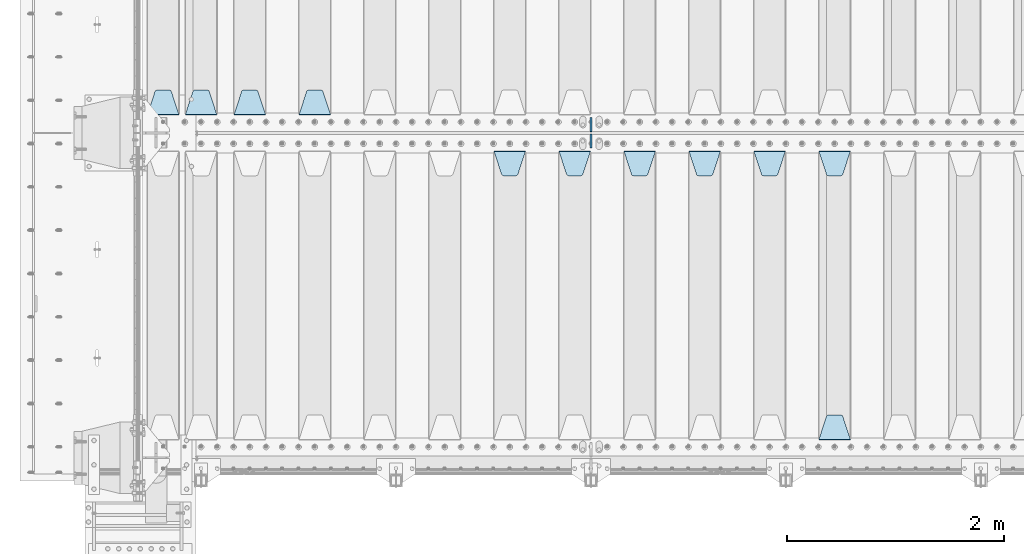
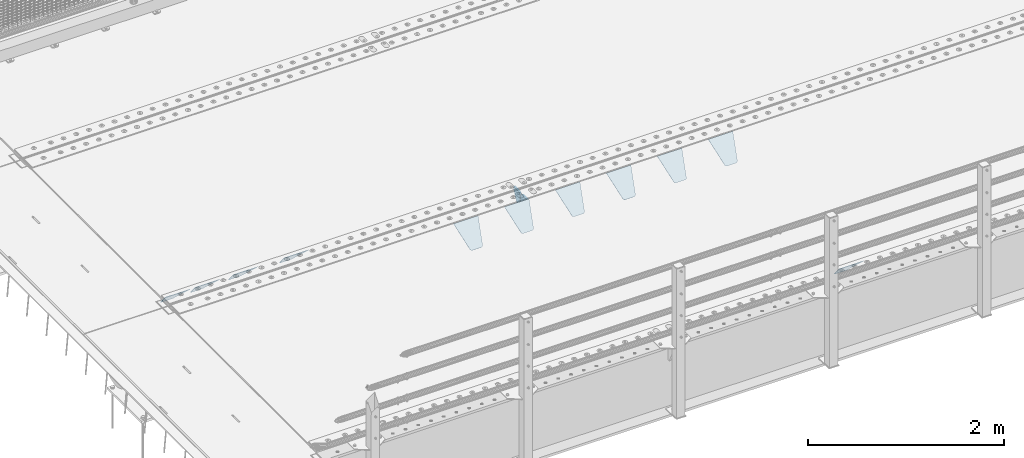
# One storey, part 177 of 219: 13 plates.
"""IFC2X3 building model written with IfcOpenShell, lengths in millimetres."""

from ifc_helpers import new_model, si_unit, frame, origin_with_axes, place, context, subcontext, project, spatial, faceted_brep, material, type_object, element, save


model = new_model("IFC2X3")

# Units and contexts
model_context = context("Model", 3, precision=1e-05, world=origin_with_axes())
body_context = subcontext(model_context, "Body", "Model", "MODEL_VIEW")
ifc_project = project(units=[si_unit("LENGTHUNIT", "METRE", prefix="MILLI"), si_unit("AREAUNIT", "SQUARE_METRE"), si_unit("VOLUMEUNIT", "CUBIC_METRE"), si_unit("MASSUNIT", "GRAM", prefix="KILO"), si_unit("TIMEUNIT", "SECOND"), si_unit("PLANEANGLEUNIT", "RADIAN"), si_unit("SOLIDANGLEUNIT", "STERADIAN"), si_unit("THERMODYNAMICTEMPERATUREUNIT", "DEGREE_CELSIUS"), si_unit("LUMINOUSINTENSITYUNIT", "LUMEN")], contexts=[model_context])

# Site, building, storey
site_placement = place(None, origin_with_axes())
site = spatial("IfcSite", under=ifc_project, at=site_placement, CompositionType="ELEMENT")
building_placement = place(site_placement, origin_with_axes())
building = spatial("IfcBuilding", under=site, at=building_placement, Name="Standard", CompositionType="ELEMENT")
storey_placement = place(building_placement, origin_with_axes())
storey = spatial("IfcBuildingStorey", under=building, at=storey_placement, Name="Undefined", CompositionType="ELEMENT", Elevation=0.0)

# Plates
ifc_material = material(Name="STEEL/S355N")
plate_type_1 = type_object("IfcPlateType", PredefinedType="NOTDEFINED")
plate_1_placement = place(storey_placement, frame((6255.0, 26831.767766956, -1.76776695296758), z_axis=(0.0, -0.707106781186547, -0.707106781186548), x_axis=(1.0, 0.0, 0.0)))
element("IfcPlate", 1, at=plate_1_placement, inside=storey, type_object=plate_type_1, material=ifc_material, context=body_context, shape_type="Brep", body=[
    faceted_brep([(0.0, -2.5, 0.0), (69.345504679477, -2.5, 300.171731424834), (69.345504679477, 2.49999999999636, 300.171731424831), (0.0, 2.5, 0.0), (70.9274061199576, -2.50000000000364, 304.8974424154), (70.9274061199576, 2.49999999999636, 304.8974424154), (73.3818627772307, -2.50000000000364, 309.234538108532), (73.3818627772307, 2.49999999999636, 309.234538108532), (76.6187032999569, -2.50000000000364, 313.023683126106), (76.6187032999569, 2.49999999999636, 313.023683126106), (80.5190132704993, -2.50000000000364, 316.125672595372), (80.5190132704993, 2.49999999999636, 316.125672595372), (84.9395038596831, -2.50000000000364, 318.426546230476), (84.9395038596831, 2.5, 318.426546230479), (89.7177759439237, -2.50000000000364, 319.841774983277), (89.7177759439237, 2.5, 319.841774983281), (94.6782862926502, -2.50000000000364, 320.319366455078), (94.6782862926502, 2.49999999999636, 320.319366455078), (195.32171370735, -2.50000000000364, 320.319366455078), (195.32171370735, 2.49999999999636, 320.319366455078), (200.282224056076, -2.50000000000364, 319.841774983277), (200.282224056076, 2.5, 319.841774983281), (205.060496140317, -2.50000000000364, 318.426546230476), (205.060496140317, 2.49999999999636, 318.426546230476), (209.480986729501, -2.50000000000364, 316.125672595372), (209.480986729501, 2.49999999999636, 316.125672595372), (213.381296700043, -2.50000000000364, 313.023683126106), (213.381296700043, 2.49999999999272, 313.023683126106), (216.618137222769, -2.50000000000364, 309.234538108529), (216.618137222769, 2.49999999999636, 309.234538108525), (219.072593880042, -2.50000000000364, 304.8974424154), (219.072593880042, 2.49999999999636, 304.8974424154), (220.654495320523, -2.5, 300.171731424834), (220.654495320523, 2.49999999999636, 300.171731424831), (290.0, -2.50000000000364, 3.63797880709171e-12), (290.0, 2.49999999999636, 0.0)], [[[0, 1, 2, 3]], [[1, 4, 5, 2]], [[4, 6, 7, 5]], [[6, 8, 9, 7]], [[8, 10, 11, 9]], [[10, 12, 13, 11]], [[12, 14, 15, 13]], [[14, 16, 17, 15]], [[16, 18, 19, 17]], [[18, 20, 21, 19]], [[20, 22, 23, 21]], [[22, 24, 25, 23]], [[24, 26, 27, 25]], [[26, 28, 29, 27]], [[28, 30, 31, 29]], [[30, 32, 33, 31]], [[32, 34, 35, 33]], [[34, 0, 3, 35]], [[5, 7, 9, 11, 13, 15, 17, 19, 21, 23, 25, 27, 29, 31, 33, 35, 3, 2]], [[34, 32, 30, 28, 26, 24, 22, 20, 18, 16, 14, 12, 10, 8, 6, 4, 1, 0]]]),
])
plate_2_placement = place(storey_placement, frame((6545.0, 24168.232233047, -1.76776695296758), z_axis=(0.0, 0.707106781186547, -0.707106781186548), x_axis=(-1.0, 0.0, 0.0)))
element("IfcPlate", 2, at=plate_2_placement, inside=storey, type_object=plate_type_1, material=ifc_material, context=body_context, shape_type="Brep", body=[
    faceted_brep([(0.0, -2.5, 0.0), (69.345504679477, -2.5, 300.171731424834), (69.345504679477, 2.49999999999636, 300.171731424831), (0.0, 2.5, 0.0), (70.9274061199576, -2.50000000000364, 304.8974424154), (70.9274061199576, 2.49999999999636, 304.8974424154), (73.3818627772307, -2.50000000000364, 309.234538108532), (73.3818627772307, 2.49999999999636, 309.234538108532), (76.6187032999569, -2.50000000000364, 313.023683126106), (76.6187032999569, 2.49999999999636, 313.023683126106), (80.5190132704993, -2.50000000000364, 316.125672595372), (80.5190132704993, 2.49999999999636, 316.125672595372), (84.9395038596831, -2.50000000000364, 318.426546230476), (84.9395038596831, 2.5, 318.426546230479), (89.7177759439237, -2.50000000000364, 319.841774983277), (89.7177759439237, 2.5, 319.841774983281), (94.6782862926502, -2.50000000000364, 320.319366455078), (94.6782862926502, 2.49999999999636, 320.319366455078), (195.32171370735, -2.50000000000364, 320.319366455078), (195.32171370735, 2.49999999999636, 320.319366455078), (200.282224056076, -2.50000000000364, 319.841774983277), (200.282224056076, 2.5, 319.841774983281), (205.060496140317, -2.50000000000364, 318.426546230476), (205.060496140317, 2.49999999999636, 318.426546230476), (209.480986729501, -2.50000000000364, 316.125672595372), (209.480986729501, 2.49999999999636, 316.125672595372), (213.381296700043, -2.50000000000364, 313.023683126106), (213.381296700043, 2.49999999999272, 313.023683126106), (216.618137222769, -2.50000000000364, 309.234538108529), (216.618137222769, 2.49999999999636, 309.234538108525), (219.072593880042, -2.50000000000364, 304.8974424154), (219.072593880042, 2.49999999999636, 304.8974424154), (220.654495320523, -2.5, 300.171731424834), (220.654495320523, 2.49999999999636, 300.171731424831), (290.0, -2.50000000000364, 3.63797880709171e-12), (290.0, 2.49999999999636, 0.0)], [[[0, 1, 2, 3]], [[1, 4, 5, 2]], [[4, 6, 7, 5]], [[6, 8, 9, 7]], [[8, 10, 11, 9]], [[10, 12, 13, 11]], [[12, 14, 15, 13]], [[14, 16, 17, 15]], [[16, 18, 19, 17]], [[18, 20, 21, 19]], [[20, 22, 23, 21]], [[22, 24, 25, 23]], [[24, 26, 27, 25]], [[26, 28, 29, 27]], [[28, 30, 31, 29]], [[30, 32, 33, 31]], [[32, 34, 35, 33]], [[34, 0, 3, 35]], [[5, 7, 9, 11, 13, 15, 17, 19, 21, 23, 25, 27, 29, 31, 33, 35, 3, 2]], [[34, 32, 30, 28, 26, 24, 22, 20, 18, 16, 14, 12, 10, 8, 6, 4, 1, 0]]]),
])
plate_3_placement = place(storey_placement, frame((5655.0, 26831.767766956, -1.76776695296758), z_axis=(0.0, -0.707106781186547, -0.707106781186548), x_axis=(1.0, 0.0, 0.0)))
element("IfcPlate", 3, at=plate_3_placement, inside=storey, type_object=plate_type_1, material=ifc_material, context=body_context, shape_type="Brep", body=[
    faceted_brep([(0.0, -2.5, 0.0), (69.345504679477, -2.5, 300.171731424834), (69.345504679477, 2.49999999999636, 300.171731424831), (0.0, 2.5, 0.0), (70.9274061199576, -2.50000000000364, 304.8974424154), (70.9274061199576, 2.49999999999636, 304.8974424154), (73.3818627772307, -2.50000000000364, 309.234538108532), (73.3818627772307, 2.49999999999636, 309.234538108532), (76.6187032999569, -2.50000000000364, 313.023683126106), (76.6187032999569, 2.49999999999636, 313.023683126106), (80.5190132704993, -2.50000000000364, 316.125672595372), (80.5190132704993, 2.49999999999636, 316.125672595372), (84.9395038596831, -2.50000000000364, 318.426546230476), (84.9395038596831, 2.5, 318.426546230479), (89.7177759439237, -2.50000000000364, 319.841774983277), (89.7177759439237, 2.5, 319.841774983281), (94.6782862926502, -2.50000000000364, 320.319366455078), (94.6782862926502, 2.49999999999636, 320.319366455078), (195.32171370735, -2.50000000000364, 320.319366455078), (195.32171370735, 2.49999999999636, 320.319366455078), (200.282224056076, -2.50000000000364, 319.841774983277), (200.282224056076, 2.5, 319.841774983281), (205.060496140317, -2.50000000000364, 318.426546230476), (205.060496140317, 2.49999999999636, 318.426546230476), (209.480986729501, -2.50000000000364, 316.125672595372), (209.480986729501, 2.49999999999636, 316.125672595372), (213.381296700043, -2.50000000000364, 313.023683126106), (213.381296700043, 2.49999999999272, 313.023683126106), (216.618137222769, -2.50000000000364, 309.234538108529), (216.618137222769, 2.49999999999636, 309.234538108525), (219.072593880042, -2.50000000000364, 304.8974424154), (219.072593880042, 2.49999999999636, 304.8974424154), (220.654495320523, -2.5, 300.171731424834), (220.654495320523, 2.49999999999636, 300.171731424831), (290.0, -2.50000000000364, 3.63797880709171e-12), (290.0, 2.49999999999636, 0.0)], [[[0, 1, 2, 3]], [[1, 4, 5, 2]], [[4, 6, 7, 5]], [[6, 8, 9, 7]], [[8, 10, 11, 9]], [[10, 12, 13, 11]], [[12, 14, 15, 13]], [[14, 16, 17, 15]], [[16, 18, 19, 17]], [[18, 20, 21, 19]], [[20, 22, 23, 21]], [[22, 24, 25, 23]], [[24, 26, 27, 25]], [[26, 28, 29, 27]], [[28, 30, 31, 29]], [[30, 32, 33, 31]], [[32, 34, 35, 33]], [[34, 0, 3, 35]], [[5, 7, 9, 11, 13, 15, 17, 19, 21, 23, 25, 27, 29, 31, 33, 35, 3, 2]], [[34, 32, 30, 28, 26, 24, 22, 20, 18, 16, 14, 12, 10, 8, 6, 4, 1, 0]]]),
])
plate_4_placement = place(storey_placement, frame((5055.0, 26831.767766956, -1.76776695296758), z_axis=(0.0, -0.707106781186547, -0.707106781186548), x_axis=(1.0, 0.0, 0.0)))
element("IfcPlate", 4, at=plate_4_placement, inside=storey, type_object=plate_type_1, material=ifc_material, context=body_context, shape_type="Brep", body=[
    faceted_brep([(0.0, -2.5, 0.0), (69.345504679477, -2.5, 300.171731424834), (69.345504679477, 2.49999999999636, 300.171731424831), (0.0, 2.5, 0.0), (70.9274061199576, -2.50000000000364, 304.8974424154), (70.9274061199576, 2.49999999999636, 304.8974424154), (73.3818627772307, -2.50000000000364, 309.234538108532), (73.3818627772307, 2.49999999999636, 309.234538108532), (76.6187032999569, -2.50000000000364, 313.023683126106), (76.6187032999569, 2.49999999999636, 313.023683126106), (80.5190132704993, -2.50000000000364, 316.125672595372), (80.5190132704993, 2.49999999999636, 316.125672595372), (84.9395038596831, -2.50000000000364, 318.426546230476), (84.9395038596831, 2.5, 318.426546230479), (89.7177759439237, -2.50000000000364, 319.841774983277), (89.7177759439237, 2.5, 319.841774983281), (94.6782862926502, -2.50000000000364, 320.319366455078), (94.6782862926502, 2.49999999999636, 320.319366455078), (195.32171370735, -2.50000000000364, 320.319366455078), (195.32171370735, 2.49999999999636, 320.319366455078), (200.282224056076, -2.50000000000364, 319.841774983277), (200.282224056076, 2.5, 319.841774983281), (205.060496140317, -2.50000000000364, 318.426546230476), (205.060496140317, 2.49999999999636, 318.426546230476), (209.480986729501, -2.50000000000364, 316.125672595372), (209.480986729501, 2.49999999999636, 316.125672595372), (213.381296700043, -2.50000000000364, 313.023683126106), (213.381296700043, 2.49999999999272, 313.023683126106), (216.618137222769, -2.50000000000364, 309.234538108529), (216.618137222769, 2.49999999999636, 309.234538108525), (219.072593880042, -2.50000000000364, 304.8974424154), (219.072593880042, 2.49999999999636, 304.8974424154), (220.654495320523, -2.5, 300.171731424834), (220.654495320523, 2.49999999999636, 300.171731424831), (290.0, -2.50000000000364, 3.63797880709171e-12), (290.0, 2.49999999999636, 0.0)], [[[0, 1, 2, 3]], [[1, 4, 5, 2]], [[4, 6, 7, 5]], [[6, 8, 9, 7]], [[8, 10, 11, 9]], [[10, 12, 13, 11]], [[12, 14, 15, 13]], [[14, 16, 17, 15]], [[16, 18, 19, 17]], [[18, 20, 21, 19]], [[20, 22, 23, 21]], [[22, 24, 25, 23]], [[24, 26, 27, 25]], [[26, 28, 29, 27]], [[28, 30, 31, 29]], [[30, 32, 33, 31]], [[32, 34, 35, 33]], [[34, 0, 3, 35]], [[5, 7, 9, 11, 13, 15, 17, 19, 21, 23, 25, 27, 29, 31, 33, 35, 3, 2]], [[34, 32, 30, 28, 26, 24, 22, 20, 18, 16, 14, 12, 10, 8, 6, 4, 1, 0]]]),
])
plate_5_placement = place(storey_placement, frame((4455.0, 26831.767766956, -1.76776695296758), z_axis=(0.0, -0.707106781186547, -0.707106781186548), x_axis=(1.0, 0.0, 0.0)))
element("IfcPlate", 5, at=plate_5_placement, inside=storey, type_object=plate_type_1, material=ifc_material, context=body_context, shape_type="Brep", body=[
    faceted_brep([(0.0, -2.5, 0.0), (69.345504679477, -2.5, 300.171731424834), (69.345504679477, 2.49999999999636, 300.171731424831), (0.0, 2.5, 0.0), (70.9274061199576, -2.50000000000364, 304.8974424154), (70.9274061199576, 2.49999999999636, 304.8974424154), (73.3818627772307, -2.50000000000364, 309.234538108532), (73.3818627772307, 2.49999999999636, 309.234538108532), (76.6187032999569, -2.50000000000364, 313.023683126106), (76.6187032999569, 2.49999999999636, 313.023683126106), (80.5190132704993, -2.50000000000364, 316.125672595372), (80.5190132704993, 2.49999999999636, 316.125672595372), (84.9395038596831, -2.50000000000364, 318.426546230476), (84.9395038596831, 2.5, 318.426546230479), (89.7177759439237, -2.50000000000364, 319.841774983277), (89.7177759439237, 2.5, 319.841774983281), (94.6782862926502, -2.50000000000364, 320.319366455078), (94.6782862926502, 2.49999999999636, 320.319366455078), (195.32171370735, -2.50000000000364, 320.319366455078), (195.32171370735, 2.49999999999636, 320.319366455078), (200.282224056076, -2.50000000000364, 319.841774983277), (200.282224056076, 2.5, 319.841774983281), (205.060496140317, -2.50000000000364, 318.426546230476), (205.060496140317, 2.49999999999636, 318.426546230476), (209.480986729501, -2.50000000000364, 316.125672595372), (209.480986729501, 2.49999999999636, 316.125672595372), (213.381296700043, -2.50000000000364, 313.023683126106), (213.381296700043, 2.49999999999272, 313.023683126106), (216.618137222769, -2.50000000000364, 309.234538108529), (216.618137222769, 2.49999999999636, 309.234538108525), (219.072593880042, -2.50000000000364, 304.8974424154), (219.072593880042, 2.49999999999636, 304.8974424154), (220.654495320523, -2.5, 300.171731424834), (220.654495320523, 2.49999999999636, 300.171731424831), (290.0, -2.50000000000364, 3.63797880709171e-12), (290.0, 2.49999999999636, 0.0)], [[[0, 1, 2, 3]], [[1, 4, 5, 2]], [[4, 6, 7, 5]], [[6, 8, 9, 7]], [[8, 10, 11, 9]], [[10, 12, 13, 11]], [[12, 14, 15, 13]], [[14, 16, 17, 15]], [[16, 18, 19, 17]], [[18, 20, 21, 19]], [[20, 22, 23, 21]], [[22, 24, 25, 23]], [[24, 26, 27, 25]], [[26, 28, 29, 27]], [[28, 30, 31, 29]], [[30, 32, 33, 31]], [[32, 34, 35, 33]], [[34, 0, 3, 35]], [[5, 7, 9, 11, 13, 15, 17, 19, 21, 23, 25, 27, 29, 31, 33, 35, 3, 2]], [[34, 32, 30, 28, 26, 24, 22, 20, 18, 16, 14, 12, 10, 8, 6, 4, 1, 0]]]),
])
plate_6_placement = place(storey_placement, frame((3855.0, 26831.767766956, -1.76776695296758), z_axis=(0.0, -0.707106781186547, -0.707106781186548), x_axis=(1.0, 0.0, 0.0)))
element("IfcPlate", 6, at=plate_6_placement, inside=storey, type_object=plate_type_1, material=ifc_material, context=body_context, shape_type="Brep", body=[
    faceted_brep([(0.0, -2.5, 0.0), (69.345504679477, -2.5, 300.171731424834), (69.345504679477, 2.49999999999636, 300.171731424831), (0.0, 2.5, 0.0), (70.9274061199576, -2.50000000000364, 304.8974424154), (70.9274061199576, 2.49999999999636, 304.8974424154), (73.3818627772307, -2.50000000000364, 309.234538108532), (73.3818627772307, 2.49999999999636, 309.234538108532), (76.6187032999569, -2.50000000000364, 313.023683126106), (76.6187032999569, 2.49999999999636, 313.023683126106), (80.5190132704993, -2.50000000000364, 316.125672595372), (80.5190132704993, 2.49999999999636, 316.125672595372), (84.9395038596831, -2.50000000000364, 318.426546230476), (84.9395038596831, 2.5, 318.426546230479), (89.7177759439237, -2.50000000000364, 319.841774983277), (89.7177759439237, 2.5, 319.841774983281), (94.6782862926502, -2.50000000000364, 320.319366455078), (94.6782862926502, 2.49999999999636, 320.319366455078), (195.32171370735, -2.50000000000364, 320.319366455078), (195.32171370735, 2.49999999999636, 320.319366455078), (200.282224056076, -2.50000000000364, 319.841774983277), (200.282224056076, 2.5, 319.841774983281), (205.060496140317, -2.50000000000364, 318.426546230476), (205.060496140317, 2.49999999999636, 318.426546230476), (209.480986729501, -2.50000000000364, 316.125672595372), (209.480986729501, 2.49999999999636, 316.125672595372), (213.381296700043, -2.50000000000364, 313.023683126106), (213.381296700043, 2.49999999999272, 313.023683126106), (216.618137222769, -2.50000000000364, 309.234538108529), (216.618137222769, 2.49999999999636, 309.234538108525), (219.072593880042, -2.50000000000364, 304.8974424154), (219.072593880042, 2.49999999999636, 304.8974424154), (220.654495320523, -2.5, 300.171731424834), (220.654495320523, 2.49999999999636, 300.171731424831), (290.0, -2.50000000000364, 3.63797880709171e-12), (290.0, 2.49999999999636, 0.0)], [[[0, 1, 2, 3]], [[1, 4, 5, 2]], [[4, 6, 7, 5]], [[6, 8, 9, 7]], [[8, 10, 11, 9]], [[10, 12, 13, 11]], [[12, 14, 15, 13]], [[14, 16, 17, 15]], [[16, 18, 19, 17]], [[18, 20, 21, 19]], [[20, 22, 23, 21]], [[22, 24, 25, 23]], [[24, 26, 27, 25]], [[26, 28, 29, 27]], [[28, 30, 31, 29]], [[30, 32, 33, 31]], [[32, 34, 35, 33]], [[34, 0, 3, 35]], [[5, 7, 9, 11, 13, 15, 17, 19, 21, 23, 25, 27, 29, 31, 33, 35, 3, 2]], [[34, 32, 30, 28, 26, 24, 22, 20, 18, 16, 14, 12, 10, 8, 6, 4, 1, 0]]]),
])
plate_7_placement = place(storey_placement, frame((3255.0, 26831.767766956, -1.76776695296758), z_axis=(0.0, -0.707106781186547, -0.707106781186548), x_axis=(1.0, 0.0, 0.0)))
element("IfcPlate", 7, at=plate_7_placement, inside=storey, type_object=plate_type_1, material=ifc_material, context=body_context, shape_type="Brep", body=[
    faceted_brep([(0.0, -2.5, 0.0), (69.345504679477, -2.5, 300.171731424834), (69.345504679477, 2.49999999999636, 300.171731424831), (0.0, 2.5, 0.0), (70.9274061199576, -2.50000000000364, 304.8974424154), (70.9274061199576, 2.49999999999636, 304.8974424154), (73.3818627772307, -2.50000000000364, 309.234538108532), (73.3818627772307, 2.49999999999636, 309.234538108532), (76.6187032999569, -2.50000000000364, 313.023683126106), (76.6187032999569, 2.49999999999636, 313.023683126106), (80.5190132704993, -2.50000000000364, 316.125672595372), (80.5190132704993, 2.49999999999636, 316.125672595372), (84.9395038596831, -2.50000000000364, 318.426546230476), (84.9395038596831, 2.5, 318.426546230479), (89.7177759439237, -2.50000000000364, 319.841774983277), (89.7177759439237, 2.5, 319.841774983281), (94.6782862926502, -2.50000000000364, 320.319366455078), (94.6782862926502, 2.49999999999636, 320.319366455078), (195.32171370735, -2.50000000000364, 320.319366455078), (195.32171370735, 2.49999999999636, 320.319366455078), (200.282224056076, -2.50000000000364, 319.841774983277), (200.282224056076, 2.5, 319.841774983281), (205.060496140317, -2.50000000000364, 318.426546230476), (205.060496140317, 2.49999999999636, 318.426546230476), (209.480986729501, -2.50000000000364, 316.125672595372), (209.480986729501, 2.49999999999636, 316.125672595372), (213.381296700043, -2.50000000000364, 313.023683126106), (213.381296700043, 2.49999999999272, 313.023683126106), (216.618137222769, -2.50000000000364, 309.234538108529), (216.618137222769, 2.49999999999636, 309.234538108525), (219.072593880042, -2.50000000000364, 304.8974424154), (219.072593880042, 2.49999999999636, 304.8974424154), (220.654495320523, -2.5, 300.171731424834), (220.654495320523, 2.49999999999636, 300.171731424831), (290.0, -2.50000000000364, 3.63797880709171e-12), (290.0, 2.49999999999636, 0.0)], [[[0, 1, 2, 3]], [[1, 4, 5, 2]], [[4, 6, 7, 5]], [[6, 8, 9, 7]], [[8, 10, 11, 9]], [[10, 12, 13, 11]], [[12, 14, 15, 13]], [[14, 16, 17, 15]], [[16, 18, 19, 17]], [[18, 20, 21, 19]], [[20, 22, 23, 21]], [[22, 24, 25, 23]], [[24, 26, 27, 25]], [[26, 28, 29, 27]], [[28, 30, 31, 29]], [[30, 32, 33, 31]], [[32, 34, 35, 33]], [[34, 0, 3, 35]], [[5, 7, 9, 11, 13, 15, 17, 19, 21, 23, 25, 27, 29, 31, 33, 35, 3, 2]], [[34, 32, 30, 28, 26, 24, 22, 20, 18, 16, 14, 12, 10, 8, 6, 4, 1, 0]]]),
])
plate_8_placement = place(storey_placement, frame((1745.0, 27168.232233047, -1.76776695296758), z_axis=(0.0, 0.707106781186547, -0.707106781186548), x_axis=(-1.0, 0.0, 0.0)))
element("IfcPlate", 8, at=plate_8_placement, inside=storey, type_object=plate_type_1, material=ifc_material, context=body_context, shape_type="Brep", body=[
    faceted_brep([(0.0, -2.5, 0.0), (69.345504679477, -2.5, 300.171731424834), (69.345504679477, 2.49999999999636, 300.171731424831), (0.0, 2.5, 0.0), (70.9274061199576, -2.50000000000364, 304.8974424154), (70.9274061199576, 2.49999999999636, 304.8974424154), (73.3818627772307, -2.50000000000364, 309.234538108532), (73.3818627772307, 2.49999999999636, 309.234538108532), (76.6187032999569, -2.50000000000364, 313.023683126106), (76.6187032999569, 2.49999999999636, 313.023683126106), (80.5190132704993, -2.50000000000364, 316.125672595372), (80.5190132704993, 2.49999999999636, 316.125672595372), (84.9395038596831, -2.50000000000364, 318.426546230476), (84.9395038596831, 2.5, 318.426546230479), (89.7177759439237, -2.50000000000364, 319.841774983277), (89.7177759439237, 2.5, 319.841774983281), (94.6782862926502, -2.50000000000364, 320.319366455078), (94.6782862926502, 2.49999999999636, 320.319366455078), (195.32171370735, -2.50000000000364, 320.319366455078), (195.32171370735, 2.49999999999636, 320.319366455078), (200.282224056076, -2.50000000000364, 319.841774983277), (200.282224056076, 2.5, 319.841774983281), (205.060496140317, -2.50000000000364, 318.426546230476), (205.060496140317, 2.49999999999636, 318.426546230476), (209.480986729501, -2.50000000000364, 316.125672595372), (209.480986729501, 2.49999999999636, 316.125672595372), (213.381296700043, -2.50000000000364, 313.023683126106), (213.381296700043, 2.49999999999272, 313.023683126106), (216.618137222769, -2.50000000000364, 309.234538108529), (216.618137222769, 2.49999999999636, 309.234538108525), (219.072593880042, -2.50000000000364, 304.8974424154), (219.072593880042, 2.49999999999636, 304.8974424154), (220.654495320523, -2.5, 300.171731424834), (220.654495320523, 2.49999999999636, 300.171731424831), (290.0, -2.50000000000364, 3.63797880709171e-12), (290.0, 2.49999999999636, 0.0)], [[[0, 1, 2, 3]], [[1, 4, 5, 2]], [[4, 6, 7, 5]], [[6, 8, 9, 7]], [[8, 10, 11, 9]], [[10, 12, 13, 11]], [[12, 14, 15, 13]], [[14, 16, 17, 15]], [[16, 18, 19, 17]], [[18, 20, 21, 19]], [[20, 22, 23, 21]], [[22, 24, 25, 23]], [[24, 26, 27, 25]], [[26, 28, 29, 27]], [[28, 30, 31, 29]], [[30, 32, 33, 31]], [[32, 34, 35, 33]], [[34, 0, 3, 35]], [[5, 7, 9, 11, 13, 15, 17, 19, 21, 23, 25, 27, 29, 31, 33, 35, 3, 2]], [[34, 32, 30, 28, 26, 24, 22, 20, 18, 16, 14, 12, 10, 8, 6, 4, 1, 0]]]),
])
plate_9_placement = place(storey_placement, frame((1145.0, 27168.232233047, -1.76776695296758), z_axis=(0.0, 0.707106781186547, -0.707106781186548), x_axis=(-1.0, 0.0, 0.0)))
element("IfcPlate", 9, at=plate_9_placement, inside=storey, type_object=plate_type_1, material=ifc_material, context=body_context, shape_type="Brep", body=[
    faceted_brep([(0.0, -2.5, 0.0), (69.345504679477, -2.5, 300.171731424834), (69.345504679477, 2.49999999999636, 300.171731424831), (0.0, 2.5, 0.0), (70.9274061199576, -2.50000000000364, 304.8974424154), (70.9274061199576, 2.49999999999636, 304.8974424154), (73.3818627772307, -2.50000000000364, 309.234538108532), (73.3818627772307, 2.49999999999636, 309.234538108532), (76.6187032999569, -2.50000000000364, 313.023683126106), (76.6187032999569, 2.49999999999636, 313.023683126106), (80.5190132704993, -2.50000000000364, 316.125672595372), (80.5190132704993, 2.49999999999636, 316.125672595372), (84.9395038596831, -2.50000000000364, 318.426546230476), (84.9395038596831, 2.5, 318.426546230479), (89.7177759439237, -2.50000000000364, 319.841774983277), (89.7177759439237, 2.5, 319.841774983281), (94.6782862926502, -2.50000000000364, 320.319366455078), (94.6782862926502, 2.49999999999636, 320.319366455078), (195.32171370735, -2.50000000000364, 320.319366455078), (195.32171370735, 2.49999999999636, 320.319366455078), (200.282224056076, -2.50000000000364, 319.841774983277), (200.282224056076, 2.5, 319.841774983281), (205.060496140317, -2.50000000000364, 318.426546230476), (205.060496140317, 2.49999999999636, 318.426546230476), (209.480986729501, -2.50000000000364, 316.125672595372), (209.480986729501, 2.49999999999636, 316.125672595372), (213.381296700043, -2.50000000000364, 313.023683126106), (213.381296700043, 2.49999999999272, 313.023683126106), (216.618137222769, -2.50000000000364, 309.234538108529), (216.618137222769, 2.49999999999636, 309.234538108525), (219.072593880042, -2.50000000000364, 304.8974424154), (219.072593880042, 2.49999999999636, 304.8974424154), (220.654495320523, -2.5, 300.171731424834), (220.654495320523, 2.49999999999636, 300.171731424831), (290.0, -2.50000000000364, 3.63797880709171e-12), (290.0, 2.49999999999636, 0.0)], [[[0, 1, 2, 3]], [[1, 4, 5, 2]], [[4, 6, 7, 5]], [[6, 8, 9, 7]], [[8, 10, 11, 9]], [[10, 12, 13, 11]], [[12, 14, 15, 13]], [[14, 16, 17, 15]], [[16, 18, 19, 17]], [[18, 20, 21, 19]], [[20, 22, 23, 21]], [[22, 24, 25, 23]], [[24, 26, 27, 25]], [[26, 28, 29, 27]], [[28, 30, 31, 29]], [[30, 32, 33, 31]], [[32, 34, 35, 33]], [[34, 0, 3, 35]], [[5, 7, 9, 11, 13, 15, 17, 19, 21, 23, 25, 27, 29, 31, 33, 35, 3, 2]], [[34, 32, 30, 28, 26, 24, 22, 20, 18, 16, 14, 12, 10, 8, 6, 4, 1, 0]]]),
])
plate_10_placement = place(storey_placement, frame((695.0, 27168.232233047, -1.76776695296758), z_axis=(0.0, 0.707106781186547, -0.707106781186548), x_axis=(-1.0, 0.0, 0.0)))
element("IfcPlate", 10, at=plate_10_placement, inside=storey, type_object=plate_type_1, material=ifc_material, context=body_context, shape_type="Brep", body=[
    faceted_brep([(0.0, -2.5, 0.0), (69.345504679477, -2.5, 300.171731424834), (69.345504679477, 2.49999999999636, 300.171731424831), (0.0, 2.5, 0.0), (70.9274061199576, -2.50000000000364, 304.8974424154), (70.9274061199576, 2.49999999999636, 304.8974424154), (73.3818627772307, -2.50000000000364, 309.234538108532), (73.3818627772307, 2.49999999999636, 309.234538108532), (76.6187032999569, -2.50000000000364, 313.023683126106), (76.6187032999569, 2.49999999999636, 313.023683126106), (80.5190132704993, -2.50000000000364, 316.125672595372), (80.5190132704993, 2.49999999999636, 316.125672595372), (84.9395038596831, -2.50000000000364, 318.426546230476), (84.9395038596831, 2.5, 318.426546230479), (89.7177759439237, -2.50000000000364, 319.841774983277), (89.7177759439237, 2.5, 319.841774983281), (94.6782862926502, -2.50000000000364, 320.319366455078), (94.6782862926502, 2.49999999999636, 320.319366455078), (195.32171370735, -2.50000000000364, 320.319366455078), (195.32171370735, 2.49999999999636, 320.319366455078), (200.282224056076, -2.50000000000364, 319.841774983277), (200.282224056076, 2.5, 319.841774983281), (205.060496140317, -2.50000000000364, 318.426546230476), (205.060496140317, 2.49999999999636, 318.426546230476), (209.480986729501, -2.50000000000364, 316.125672595372), (209.480986729501, 2.49999999999636, 316.125672595372), (213.381296700043, -2.50000000000364, 313.023683126106), (213.381296700043, 2.49999999999272, 313.023683126106), (216.618137222769, -2.50000000000364, 309.234538108529), (216.618137222769, 2.49999999999636, 309.234538108525), (219.072593880042, -2.50000000000364, 304.8974424154), (219.072593880042, 2.49999999999636, 304.8974424154), (220.654495320523, -2.5, 300.171731424834), (220.654495320523, 2.49999999999636, 300.171731424831), (290.0, -2.50000000000364, 3.63797880709171e-12), (290.0, 2.49999999999636, 0.0)], [[[0, 1, 2, 3]], [[1, 4, 5, 2]], [[4, 6, 7, 5]], [[6, 8, 9, 7]], [[8, 10, 11, 9]], [[10, 12, 13, 11]], [[12, 14, 15, 13]], [[14, 16, 17, 15]], [[16, 18, 19, 17]], [[18, 20, 21, 19]], [[20, 22, 23, 21]], [[22, 24, 25, 23]], [[24, 26, 27, 25]], [[26, 28, 29, 27]], [[28, 30, 31, 29]], [[30, 32, 33, 31]], [[32, 34, 35, 33]], [[34, 0, 3, 35]], [[5, 7, 9, 11, 13, 15, 17, 19, 21, 23, 25, 27, 29, 31, 33, 35, 3, 2]], [[34, 32, 30, 28, 26, 24, 22, 20, 18, 16, 14, 12, 10, 8, 6, 4, 1, 0]]]),
])
plate_11_placement = place(storey_placement, frame((345.0, 27168.232233047, -1.76776695296758), z_axis=(0.0, 0.707106781186547, -0.707106781186548), x_axis=(-1.0, 0.0, 0.0)))
element("IfcPlate", 11, at=plate_11_placement, inside=storey, type_object=plate_type_1, material=ifc_material, context=body_context, shape_type="Brep", body=[
    faceted_brep([(0.0, -2.5, 0.0), (69.345504679477, -2.5, 300.171731424834), (69.345504679477, 2.49999999999636, 300.171731424831), (0.0, 2.5, 0.0), (70.9274061199576, -2.50000000000364, 304.8974424154), (70.9274061199576, 2.49999999999636, 304.8974424154), (73.3818627772307, -2.50000000000364, 309.234538108532), (73.3818627772307, 2.49999999999636, 309.234538108532), (76.6187032999569, -2.50000000000364, 313.023683126106), (76.6187032999569, 2.49999999999636, 313.023683126106), (80.5190132704993, -2.50000000000364, 316.125672595372), (80.5190132704993, 2.49999999999636, 316.125672595372), (84.9395038596831, -2.50000000000364, 318.426546230476), (84.9395038596831, 2.5, 318.426546230479), (89.7177759439237, -2.50000000000364, 319.841774983277), (89.7177759439237, 2.5, 319.841774983281), (94.6782862926502, -2.50000000000364, 320.319366455078), (94.6782862926502, 2.49999999999636, 320.319366455078), (195.32171370735, -2.50000000000364, 320.319366455078), (195.32171370735, 2.49999999999636, 320.319366455078), (200.282224056076, -2.50000000000364, 319.841774983277), (200.282224056076, 2.5, 319.841774983281), (205.060496140317, -2.50000000000364, 318.426546230476), (205.060496140317, 2.49999999999636, 318.426546230476), (209.480986729501, -2.50000000000364, 316.125672595372), (209.480986729501, 2.49999999999636, 316.125672595372), (213.381296700043, -2.50000000000364, 313.023683126106), (213.381296700043, 2.49999999999272, 313.023683126106), (216.618137222769, -2.50000000000364, 309.234538108529), (216.618137222769, 2.49999999999636, 309.234538108525), (219.072593880042, -2.50000000000364, 304.8974424154), (219.072593880042, 2.49999999999636, 304.8974424154), (220.654495320523, -2.5, 300.171731424834), (220.654495320523, 2.49999999999636, 300.171731424831), (290.0, -2.50000000000364, 3.63797880709171e-12), (290.0, 2.49999999999636, 0.0)], [[[0, 1, 2, 3]], [[1, 4, 5, 2]], [[4, 6, 7, 5]], [[6, 8, 9, 7]], [[8, 10, 11, 9]], [[10, 12, 13, 11]], [[12, 14, 15, 13]], [[14, 16, 17, 15]], [[16, 18, 19, 17]], [[18, 20, 21, 19]], [[20, 22, 23, 21]], [[22, 24, 25, 23]], [[24, 26, 27, 25]], [[26, 28, 29, 27]], [[28, 30, 31, 29]], [[30, 32, 33, 31]], [[32, 34, 35, 33]], [[34, 0, 3, 35]], [[5, 7, 9, 11, 13, 15, 17, 19, 21, 23, 25, 27, 29, 31, 33, 35, 3, 2]], [[34, 32, 30, 28, 26, 24, 22, 20, 18, 16, 14, 12, 10, 8, 6, 4, 1, 0]]]),
])
plate_type_2 = type_object("IfcPlateType", PredefinedType="NOTDEFINED")
for number, where, z_axis, x_axis in (
    (12, (4150.0, 26860.0, -30.0), (0.0, 0.0, -1.0), (0.0, 1.0, 0.0)),
    (13, (4150.0, 27140.0, -30.0), (0.0, 0.0, -1.0), (0.0, -1.0, 0.0)),
):
    element("IfcPlate", number, at=place(storey_placement, frame(where, z_axis=z_axis, x_axis=x_axis)), inside=storey, type_object=plate_type_2, material=ifc_material, context=body_context, shape_type="Brep", body=[
        faceted_brep([(0.0, -10.0, 0.0), (0.0, -10.0, 30.0), (0.0, 10.0, 30.0), (0.0, 10.0, 0.0), (102.0, -10.0, 250.0), (102.0, 10.0, 250.0), (132.0, -10.0, 250.0), (132.0, 10.0, 250.0), (132.0, -10.0, 30.0), (132.0, 10.0, 30.0), (131.544232590368, -10.0, 24.790554669992), (131.544232590368, 10.0, 24.790554669992), (130.190778623579, -10.0, 19.7393957002299), (130.190778623579, 10.0, 19.7393957002299), (127.980762113533, -10.0, 15.0), (127.980762113533, 10.0, 15.0), (124.98133329357, -10.0, 10.7163717094038), (124.98133329357, 10.0, 10.7163717094038), (121.283628290596, -10.0, 7.01866670643062), (121.283628290596, 10.0, 7.01866670643062), (117.0, -10.0, 4.01923788646684), (117.0, 10.0, 4.01923788646684), (112.260604299769, -10.0, 1.80922137642278), (112.260604299769, 10.0, 1.80922137642278), (107.209445330009, -10.0, 0.455767409633722), (107.209445330009, 10.0, 0.455767409633722), (102.0, -10.0, 0.0), (102.0, 10.0, 0.0)], [[[0, 1, 2, 3]], [[1, 4, 5, 2]], [[4, 6, 7, 5]], [[6, 8, 9, 7]], [[8, 10, 11, 9]], [[10, 12, 13, 11]], [[12, 14, 15, 13]], [[14, 16, 17, 15]], [[16, 18, 19, 17]], [[18, 20, 21, 19]], [[20, 22, 23, 21]], [[22, 24, 25, 23]], [[24, 26, 27, 25]], [[26, 0, 3, 27]], [[5, 7, 9, 11, 13, 15, 17, 19, 21, 23, 25, 27, 3, 2]], [[26, 24, 22, 20, 18, 16, 14, 12, 10, 8, 6, 4, 1, 0]]]),
    ])

save(model, "model.ifc")
